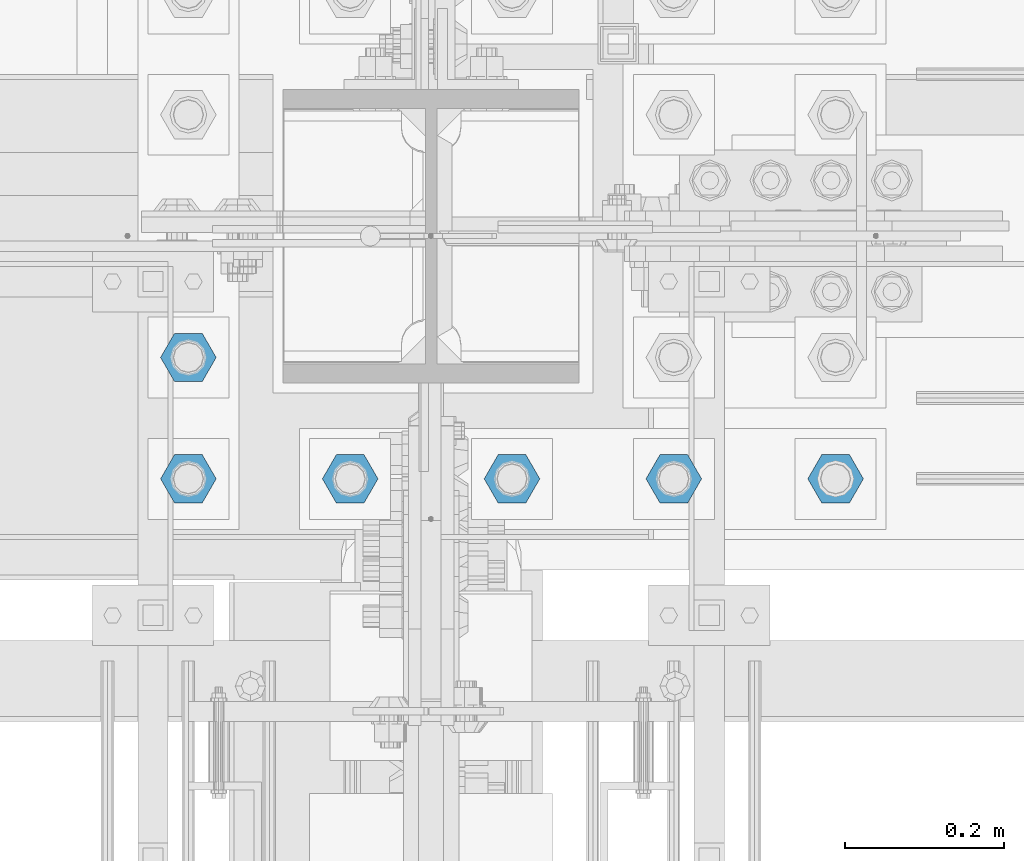
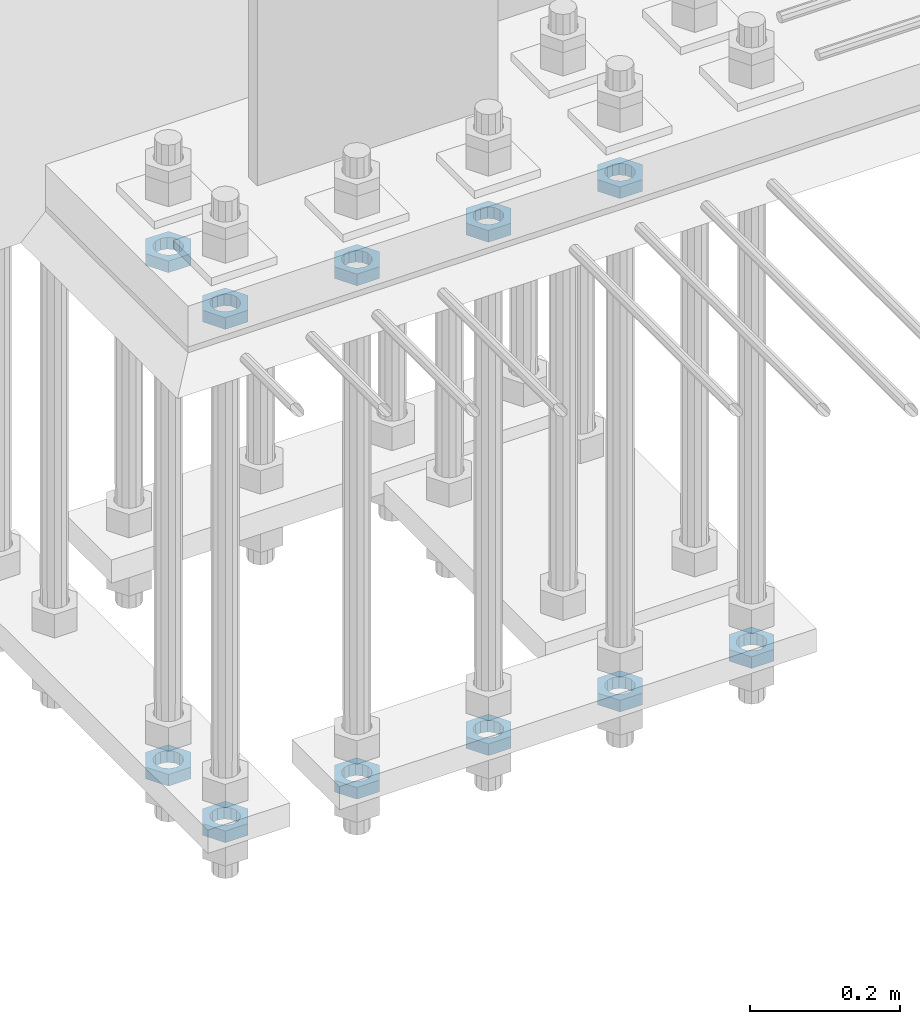
# One storey, part 2823 of 3843: 11 beams, 1 element without a shape of its own.
"""IFC2X3 building model written with IfcOpenShell, lengths in millimetres."""

from ifc_helpers import new_model, si_unit, frame, origin_with_axes, place, context, subcontext, project, spatial, faceted_brep, material, type_object, element, aggregate, save


model = new_model("IFC2X3")

# Units and contexts
model_context = context("Model", 3, precision=1e-05, world=origin_with_axes())
body_context = subcontext(model_context, "Body", "Model", "MODEL_VIEW")
ifc_project = project(units=[si_unit("LENGTHUNIT", "METRE", prefix="MILLI"), si_unit("AREAUNIT", "SQUARE_METRE"), si_unit("VOLUMEUNIT", "CUBIC_METRE"), si_unit("MASSUNIT", "GRAM", prefix="KILO"), si_unit("TIMEUNIT", "SECOND"), si_unit("PLANEANGLEUNIT", "RADIAN"), si_unit("SOLIDANGLEUNIT", "STERADIAN"), si_unit("THERMODYNAMICTEMPERATUREUNIT", "DEGREE_CELSIUS"), si_unit("LUMINOUSINTENSITYUNIT", "LUMEN")], contexts=[model_context])

# Site, building, storey
site_placement = place(None, origin_with_axes())
site = spatial("IfcSite", under=ifc_project, at=site_placement, CompositionType="ELEMENT")
building_placement = place(site_placement, origin_with_axes())
building = spatial("IfcBuilding", under=site, at=building_placement, Name="Undefined", CompositionType="ELEMENT")
storey_placement = place(building_placement, origin_with_axes())
storey = spatial("IfcBuildingStorey", under=building, at=storey_placement, Name="Undefined", CompositionType="ELEMENT", Elevation=0.0)

# Assembly, beams
assembly_placement = place(storey_placement, origin_with_axes())
assembly = element("IfcElementAssembly", 1, at=assembly_placement, inside=storey, Name="TEMPLATE", AssemblyPlace="NOTDEFINED", PredefinedType="RIGID_FRAME")
ifc_material = material(Name="STEEL/A572-50")
beam_type = type_object("IfcBeamType", Name="1-1/2_HALF_NUT", PredefinedType="NOTDEFINED")
beam_1_placement = place(assembly_placement, frame((56235.6, 25311.1, 29603.7), z_axis=(0.0, 1.0, 0.0), x_axis=(0.0, 0.0, -1.0)))
beam_1 = element("IfcBeam", 2, at=beam_1_placement, type_object=beam_type, material=ifc_material, Name="NUT", ObjectType="1-1/2_HALF_NUT", context=body_context, shape_type="Brep", body=[
    faceted_brep([(0.0, -34.9199981689453, 0.0), (0.0, -17.4599990844727, -30.25), (19.0500000000029, -17.4599990844727, -30.25), (19.0500000000029, -34.9199981689453, 0.0), (0.0, 17.4599990844727, -30.25), (19.0500000000029, 17.4599990844727, -30.25), (0.0, 34.9199981689453, 0.0), (19.0500000000029, 34.9199981689453, 0.0), (0.0, 17.4599990844727, 30.25), (19.0500000000029, 17.4599990844727, 30.25), (0.0, -17.4599990844727, 30.25), (19.0500000000029, -17.4599990844727, 30.25), (0.0, 0.0, 20.6399993896484), (0.0, 8.9553601105581, 18.5959968835959), (19.0500000000029, 8.95536011056538, 18.5959968835959), (19.0500000000029, 0.0, 20.6399993896484), (0.0, 16.1370013209525, 12.8688291298167), (19.0500000000029, 16.1370013209489, 12.8688291298167), (0.0, 20.1225115123816, 4.59283194104501), (19.0500000000029, 20.1225115123852, 4.59283194104501), (0.0, 20.1225115123816, -4.59283194104501), (19.0500000000029, 20.1225115123852, -4.59283194104501), (0.0, 16.1370013209525, -12.8688291298167), (19.0500000000029, 16.1370013209489, -12.8688291298167), (0.0, 8.9553601105581, -18.5959968835959), (19.0500000000029, 8.95536011056538, -18.5959968835959), (0.0, 0.0, -20.6399993896484), (19.0500000000029, 0.0, -20.6399993896484), (0.0, -8.9553601105581, -18.5959968835959), (19.0500000000029, -8.95536011056538, -18.5959968835959), (0.0, -16.1370013209525, -12.8688291298167), (19.0500000000029, -16.1370013209489, -12.8688291298167), (0.0, -20.1225115123816, -4.59283194104501), (19.0500000000029, -20.1225115123852, -4.59283194104501), (0.0, -20.1225115123816, 4.59283194104501), (19.0500000000029, -20.1225115123852, 4.59283194104501), (0.0, -16.1370013209525, 12.8688291298167), (19.0500000000029, -16.1370013209489, 12.8688291298167), (0.0, -8.9553601105581, 18.5959968835959), (19.0500000000029, -8.95536011056538, 18.5959968835959)], [[[0, 1, 2, 3]], [[1, 4, 5, 2]], [[4, 6, 7, 5]], [[6, 8, 9, 7]], [[8, 10, 11, 9]], [[10, 0, 3, 11]], [[12, 13, 14, 15]], [[13, 16, 17, 14]], [[16, 18, 19, 17]], [[18, 20, 21, 19]], [[20, 22, 23, 21]], [[22, 24, 25, 23]], [[24, 26, 27, 25]], [[26, 28, 29, 27]], [[28, 30, 31, 29]], [[30, 32, 33, 31]], [[32, 34, 35, 33]], [[34, 36, 37, 35]], [[36, 38, 39, 37]], [[38, 12, 15, 39]], [[5, 7, 9, 11, 3, 2], [17, 19, 21, 23, 25, 27, 29, 31, 33, 35, 37, 39, 15, 14]], [[10, 8, 6, 4, 1, 0], [38, 36, 34, 32, 30, 28, 26, 24, 22, 20, 18, 16, 13, 12]]]),
])
beam_2_placement = place(assembly_placement, frame((56032.4, 25311.1, 29603.7), z_axis=(0.0, -1.0, 0.0), x_axis=(0.0, 0.0, -1.0)))
beam_2 = element("IfcBeam", 3, at=beam_2_placement, type_object=beam_type, material=ifc_material, Name="NUT", ObjectType="1-1/2_HALF_NUT", context=body_context, shape_type="Brep", body=[
    faceted_brep([(0.0, -34.9199981689453, 0.0), (0.0, -17.4599990844727, -30.25), (19.0500000000029, -17.4599990844727, -30.25), (19.0500000000029, -34.9199981689453, 0.0), (0.0, 17.4599990844727, -30.25), (19.0500000000029, 17.4599990844727, -30.25), (0.0, 34.9199981689453, 0.0), (19.0500000000029, 34.9199981689453, 0.0), (0.0, 17.4599990844727, 30.25), (19.0500000000029, 17.4599990844727, 30.25), (0.0, -17.4599990844727, 30.25), (19.0500000000029, -17.4599990844727, 30.25), (0.0, 0.0, 20.6399993896484), (0.0, 8.9553601105581, 18.5959968835959), (19.0500000000029, 8.95536011056538, 18.5959968835959), (19.0500000000029, 0.0, 20.6399993896484), (0.0, 16.1370013209525, 12.8688291298167), (19.0500000000029, 16.1370013209489, 12.8688291298167), (0.0, 20.1225115123816, 4.59283194104501), (19.0500000000029, 20.1225115123852, 4.59283194104501), (0.0, 20.1225115123816, -4.59283194104501), (19.0500000000029, 20.1225115123852, -4.59283194104501), (0.0, 16.1370013209525, -12.8688291298167), (19.0500000000029, 16.1370013209489, -12.8688291298167), (0.0, 8.9553601105581, -18.5959968835959), (19.0500000000029, 8.95536011056538, -18.5959968835959), (0.0, 0.0, -20.6399993896484), (19.0500000000029, 0.0, -20.6399993896484), (0.0, -8.9553601105581, -18.5959968835959), (19.0500000000029, -8.95536011056538, -18.5959968835959), (0.0, -16.1370013209525, -12.8688291298167), (19.0500000000029, -16.1370013209489, -12.8688291298167), (0.0, -20.1225115123816, -4.59283194104501), (19.0500000000029, -20.1225115123852, -4.59283194104501), (0.0, -20.1225115123816, 4.59283194104501), (19.0500000000029, -20.1225115123852, 4.59283194104501), (0.0, -16.1370013209525, 12.8688291298167), (19.0500000000029, -16.1370013209489, 12.8688291298167), (0.0, -8.9553601105581, 18.5959968835959), (19.0500000000029, -8.95536011056538, 18.5959968835959)], [[[0, 1, 2, 3]], [[1, 4, 5, 2]], [[4, 6, 7, 5]], [[6, 8, 9, 7]], [[8, 10, 11, 9]], [[10, 0, 3, 11]], [[12, 13, 14, 15]], [[13, 16, 17, 14]], [[16, 18, 19, 17]], [[18, 20, 21, 19]], [[20, 22, 23, 21]], [[22, 24, 25, 23]], [[24, 26, 27, 25]], [[26, 28, 29, 27]], [[28, 30, 31, 29]], [[30, 32, 33, 31]], [[32, 34, 35, 33]], [[34, 36, 37, 35]], [[36, 38, 39, 37]], [[38, 12, 15, 39]], [[5, 7, 9, 11, 3, 2], [17, 19, 21, 23, 25, 27, 29, 31, 33, 35, 37, 39, 15, 14]], [[10, 8, 6, 4, 1, 0], [38, 36, 34, 32, 30, 28, 26, 24, 22, 20, 18, 16, 13, 12]]]),
])
beam_3_placement = place(assembly_placement, frame((55829.2, 25311.1, 29603.7), z_axis=(0.0, -1.0, 0.0), x_axis=(0.0, 0.0, -1.0)))
beam_3 = element("IfcBeam", 4, at=beam_3_placement, type_object=beam_type, material=ifc_material, Name="NUT", ObjectType="1-1/2_HALF_NUT", context=body_context, shape_type="Brep", body=[
    faceted_brep([(0.0, -34.9199981689453, 0.0), (0.0, -17.4599990844727, -30.25), (19.0500000000029, -17.4599990844727, -30.25), (19.0500000000029, -34.9199981689453, 0.0), (0.0, 17.4599990844727, -30.25), (19.0500000000029, 17.4599990844727, -30.25), (0.0, 34.9199981689453, 0.0), (19.0500000000029, 34.9199981689453, 0.0), (0.0, 17.4599990844727, 30.25), (19.0500000000029, 17.4599990844727, 30.25), (0.0, -17.4599990844727, 30.25), (19.0500000000029, -17.4599990844727, 30.25), (0.0, 0.0, 20.6399993896484), (0.0, 8.9553601105581, 18.5959968835959), (19.0500000000029, 8.95536011056538, 18.5959968835959), (19.0500000000029, 0.0, 20.6399993896484), (0.0, 16.1370013209525, 12.8688291298167), (19.0500000000029, 16.1370013209489, 12.8688291298167), (0.0, 20.1225115123816, 4.59283194104501), (19.0500000000029, 20.1225115123852, 4.59283194104501), (0.0, 20.1225115123816, -4.59283194104501), (19.0500000000029, 20.1225115123852, -4.59283194104501), (0.0, 16.1370013209525, -12.8688291298167), (19.0500000000029, 16.1370013209489, -12.8688291298167), (0.0, 8.9553601105581, -18.5959968835959), (19.0500000000029, 8.95536011056538, -18.5959968835959), (0.0, 0.0, -20.6399993896484), (19.0500000000029, 0.0, -20.6399993896484), (0.0, -8.9553601105581, -18.5959968835959), (19.0500000000029, -8.95536011056538, -18.5959968835959), (0.0, -16.1370013209525, -12.8688291298167), (19.0500000000029, -16.1370013209489, -12.8688291298167), (0.0, -20.1225115123816, -4.59283194104501), (19.0500000000029, -20.1225115123852, -4.59283194104501), (0.0, -20.1225115123816, 4.59283194104501), (19.0500000000029, -20.1225115123852, 4.59283194104501), (0.0, -16.1370013209525, 12.8688291298167), (19.0500000000029, -16.1370013209489, 12.8688291298167), (0.0, -8.9553601105581, 18.5959968835959), (19.0500000000029, -8.95536011056538, 18.5959968835959)], [[[0, 1, 2, 3]], [[1, 4, 5, 2]], [[4, 6, 7, 5]], [[6, 8, 9, 7]], [[8, 10, 11, 9]], [[10, 0, 3, 11]], [[12, 13, 14, 15]], [[13, 16, 17, 14]], [[16, 18, 19, 17]], [[18, 20, 21, 19]], [[20, 22, 23, 21]], [[22, 24, 25, 23]], [[24, 26, 27, 25]], [[26, 28, 29, 27]], [[28, 30, 31, 29]], [[30, 32, 33, 31]], [[32, 34, 35, 33]], [[34, 36, 37, 35]], [[36, 38, 39, 37]], [[38, 12, 15, 39]], [[5, 7, 9, 11, 3, 2], [17, 19, 21, 23, 25, 27, 29, 31, 33, 35, 37, 39, 15, 14]], [[10, 8, 6, 4, 1, 0], [38, 36, 34, 32, 30, 28, 26, 24, 22, 20, 18, 16, 13, 12]]]),
])
beam_4_placement = place(assembly_placement, frame((55626.0, 25463.5, 29603.7), z_axis=(0.0, -1.0, 0.0), x_axis=(0.0, 0.0, -1.0)))
beam_4 = element("IfcBeam", 5, at=beam_4_placement, type_object=beam_type, material=ifc_material, Name="NUT", ObjectType="1-1/2_HALF_NUT", context=body_context, shape_type="Brep", body=[
    faceted_brep([(0.0, -34.9199981689453, 0.0), (0.0, -17.4599990844727, -30.25), (19.0500000000029, -17.4599990844727, -30.25), (19.0500000000029, -34.9199981689453, 0.0), (0.0, 17.4599990844727, -30.25), (19.0500000000029, 17.4599990844727, -30.25), (0.0, 34.9199981689453, 0.0), (19.0500000000029, 34.9199981689453, 0.0), (0.0, 17.4599990844727, 30.25), (19.0500000000029, 17.4599990844727, 30.25), (0.0, -17.4599990844727, 30.25), (19.0500000000029, -17.4599990844727, 30.25), (0.0, 0.0, 20.6399993896484), (0.0, 8.9553601105581, 18.5959968835959), (19.0500000000029, 8.95536011056538, 18.5959968835959), (19.0500000000029, 0.0, 20.6399993896484), (0.0, 16.1370013209525, 12.8688291298167), (19.0500000000029, 16.1370013209489, 12.8688291298167), (0.0, 20.1225115123816, 4.59283194104501), (19.0500000000029, 20.1225115123852, 4.59283194104501), (0.0, 20.1225115123816, -4.59283194104501), (19.0500000000029, 20.1225115123852, -4.59283194104501), (0.0, 16.1370013209525, -12.8688291298167), (19.0500000000029, 16.1370013209489, -12.8688291298167), (0.0, 8.9553601105581, -18.5959968835959), (19.0500000000029, 8.95536011056538, -18.5959968835959), (0.0, 0.0, -20.6399993896484), (19.0500000000029, 0.0, -20.6399993896484), (0.0, -8.9553601105581, -18.5959968835959), (19.0500000000029, -8.95536011056538, -18.5959968835959), (0.0, -16.1370013209525, -12.8688291298167), (19.0500000000029, -16.1370013209489, -12.8688291298167), (0.0, -20.1225115123816, -4.59283194104501), (19.0500000000029, -20.1225115123852, -4.59283194104501), (0.0, -20.1225115123816, 4.59283194104501), (19.0500000000029, -20.1225115123852, 4.59283194104501), (0.0, -16.1370013209525, 12.8688291298167), (19.0500000000029, -16.1370013209489, 12.8688291298167), (0.0, -8.9553601105581, 18.5959968835959), (19.0500000000029, -8.95536011056538, 18.5959968835959)], [[[0, 1, 2, 3]], [[1, 4, 5, 2]], [[4, 6, 7, 5]], [[6, 8, 9, 7]], [[8, 10, 11, 9]], [[10, 0, 3, 11]], [[12, 13, 14, 15]], [[13, 16, 17, 14]], [[16, 18, 19, 17]], [[18, 20, 21, 19]], [[20, 22, 23, 21]], [[22, 24, 25, 23]], [[24, 26, 27, 25]], [[26, 28, 29, 27]], [[28, 30, 31, 29]], [[30, 32, 33, 31]], [[32, 34, 35, 33]], [[34, 36, 37, 35]], [[36, 38, 39, 37]], [[38, 12, 15, 39]], [[5, 7, 9, 11, 3, 2], [17, 19, 21, 23, 25, 27, 29, 31, 33, 35, 37, 39, 15, 14]], [[10, 8, 6, 4, 1, 0], [38, 36, 34, 32, 30, 28, 26, 24, 22, 20, 18, 16, 13, 12]]]),
])
beam_5_placement = place(assembly_placement, frame((55626.0, 25311.1, 29603.7), z_axis=(0.0, -1.0, 0.0), x_axis=(0.0, 0.0, -1.0)))
beam_5 = element("IfcBeam", 6, at=beam_5_placement, type_object=beam_type, material=ifc_material, Name="NUT", ObjectType="1-1/2_HALF_NUT", context=body_context, shape_type="Brep", body=[
    faceted_brep([(0.0, -34.9199981689453, 0.0), (0.0, -17.4599990844727, -30.25), (19.0500000000029, -17.4599990844727, -30.25), (19.0500000000029, -34.9199981689453, 0.0), (0.0, 17.4599990844727, -30.25), (19.0500000000029, 17.4599990844727, -30.25), (0.0, 34.9199981689453, 0.0), (19.0500000000029, 34.9199981689453, 0.0), (0.0, 17.4599990844727, 30.25), (19.0500000000029, 17.4599990844727, 30.25), (0.0, -17.4599990844727, 30.25), (19.0500000000029, -17.4599990844727, 30.25), (0.0, 0.0, 20.6399993896484), (0.0, 8.9553601105581, 18.5959968835959), (19.0500000000029, 8.95536011056538, 18.5959968835959), (19.0500000000029, 0.0, 20.6399993896484), (0.0, 16.1370013209525, 12.8688291298167), (19.0500000000029, 16.1370013209489, 12.8688291298167), (0.0, 20.1225115123816, 4.59283194104501), (19.0500000000029, 20.1225115123852, 4.59283194104501), (0.0, 20.1225115123816, -4.59283194104501), (19.0500000000029, 20.1225115123852, -4.59283194104501), (0.0, 16.1370013209525, -12.8688291298167), (19.0500000000029, 16.1370013209489, -12.8688291298167), (0.0, 8.9553601105581, -18.5959968835959), (19.0500000000029, 8.95536011056538, -18.5959968835959), (0.0, 0.0, -20.6399993896484), (19.0500000000029, 0.0, -20.6399993896484), (0.0, -8.9553601105581, -18.5959968835959), (19.0500000000029, -8.95536011056538, -18.5959968835959), (0.0, -16.1370013209525, -12.8688291298167), (19.0500000000029, -16.1370013209489, -12.8688291298167), (0.0, -20.1225115123816, -4.59283194104501), (19.0500000000029, -20.1225115123852, -4.59283194104501), (0.0, -20.1225115123816, 4.59283194104501), (19.0500000000029, -20.1225115123852, 4.59283194104501), (0.0, -16.1370013209525, 12.8688291298167), (19.0500000000029, -16.1370013209489, 12.8688291298167), (0.0, -8.9553601105581, 18.5959968835959), (19.0500000000029, -8.95536011056538, 18.5959968835959)], [[[0, 1, 2, 3]], [[1, 4, 5, 2]], [[4, 6, 7, 5]], [[6, 8, 9, 7]], [[8, 10, 11, 9]], [[10, 0, 3, 11]], [[12, 13, 14, 15]], [[13, 16, 17, 14]], [[16, 18, 19, 17]], [[18, 20, 21, 19]], [[20, 22, 23, 21]], [[22, 24, 25, 23]], [[24, 26, 27, 25]], [[26, 28, 29, 27]], [[28, 30, 31, 29]], [[30, 32, 33, 31]], [[32, 34, 35, 33]], [[34, 36, 37, 35]], [[36, 38, 39, 37]], [[38, 12, 15, 39]], [[5, 7, 9, 11, 3, 2], [17, 19, 21, 23, 25, 27, 29, 31, 33, 35, 37, 39, 15, 14]], [[10, 8, 6, 4, 1, 0], [38, 36, 34, 32, 30, 28, 26, 24, 22, 20, 18, 16, 13, 12]]]),
])
beam_6_placement = place(assembly_placement, frame((55626.0, 25311.1, 28765.5000015259), z_axis=(0.0, -1.0, 0.0), x_axis=(0.0, 0.0, -1.0)))
beam_6 = element("IfcBeam", 7, at=beam_6_placement, type_object=beam_type, material=ifc_material, Name="NUT", ObjectType="1-1/2_HALF_NUT", context=body_context, shape_type="Brep", body=[
    faceted_brep([(0.0, -34.9199981689453, 0.0), (0.0, -17.4599990844727, -30.25), (19.0500000000029, -17.4599990844727, -30.25), (19.0500000000029, -34.9199981689453, 0.0), (0.0, 17.4599990844727, -30.25), (19.0500000000029, 17.4599990844727, -30.25), (0.0, 34.9199981689453, 0.0), (19.0500000000029, 34.9199981689453, 0.0), (0.0, 17.4599990844727, 30.25), (19.0500000000029, 17.4599990844727, 30.25), (0.0, -17.4599990844727, 30.25), (19.0500000000029, -17.4599990844727, 30.25), (0.0, 0.0, 20.6399993896484), (0.0, 8.9553601105581, 18.5959968835959), (19.0500000000029, 8.95536011056538, 18.5959968835959), (19.0500000000029, 0.0, 20.6399993896484), (0.0, 16.1370013209525, 12.8688291298167), (19.0500000000029, 16.1370013209489, 12.8688291298167), (0.0, 20.1225115123816, 4.59283194104501), (19.0500000000029, 20.1225115123852, 4.59283194104501), (0.0, 20.1225115123816, -4.59283194104501), (19.0500000000029, 20.1225115123852, -4.59283194104501), (0.0, 16.1370013209525, -12.8688291298167), (19.0500000000029, 16.1370013209489, -12.8688291298167), (0.0, 8.9553601105581, -18.5959968835959), (19.0500000000029, 8.95536011056538, -18.5959968835959), (0.0, 0.0, -20.6399993896484), (19.0500000000029, 0.0, -20.6399993896484), (0.0, -8.9553601105581, -18.5959968835959), (19.0500000000029, -8.95536011056538, -18.5959968835959), (0.0, -16.1370013209525, -12.8688291298167), (19.0500000000029, -16.1370013209489, -12.8688291298167), (0.0, -20.1225115123816, -4.59283194104501), (19.0500000000029, -20.1225115123852, -4.59283194104501), (0.0, -20.1225115123816, 4.59283194104501), (19.0500000000029, -20.1225115123852, 4.59283194104501), (0.0, -16.1370013209525, 12.8688291298167), (19.0500000000029, -16.1370013209489, 12.8688291298167), (0.0, -8.9553601105581, 18.5959968835959), (19.0500000000029, -8.95536011056538, 18.5959968835959)], [[[0, 1, 2, 3]], [[1, 4, 5, 2]], [[4, 6, 7, 5]], [[6, 8, 9, 7]], [[8, 10, 11, 9]], [[10, 0, 3, 11]], [[12, 13, 14, 15]], [[13, 16, 17, 14]], [[16, 18, 19, 17]], [[18, 20, 21, 19]], [[20, 22, 23, 21]], [[22, 24, 25, 23]], [[24, 26, 27, 25]], [[26, 28, 29, 27]], [[28, 30, 31, 29]], [[30, 32, 33, 31]], [[32, 34, 35, 33]], [[34, 36, 37, 35]], [[36, 38, 39, 37]], [[38, 12, 15, 39]], [[5, 7, 9, 11, 3, 2], [17, 19, 21, 23, 25, 27, 29, 31, 33, 35, 37, 39, 15, 14]], [[10, 8, 6, 4, 1, 0], [38, 36, 34, 32, 30, 28, 26, 24, 22, 20, 18, 16, 13, 12]]]),
])
beam_7_placement = place(assembly_placement, frame((55829.2, 25311.1, 28765.5000015259), z_axis=(0.0, -1.0, 0.0), x_axis=(0.0, 0.0, -1.0)))
beam_7 = element("IfcBeam", 8, at=beam_7_placement, type_object=beam_type, material=ifc_material, Name="NUT", ObjectType="1-1/2_HALF_NUT", context=body_context, shape_type="Brep", body=[
    faceted_brep([(0.0, -34.9199981689453, 0.0), (0.0, -17.4599990844727, -30.25), (19.0500000000029, -17.4599990844727, -30.25), (19.0500000000029, -34.9199981689453, 0.0), (0.0, 17.4599990844727, -30.25), (19.0500000000029, 17.4599990844727, -30.25), (0.0, 34.9199981689453, 0.0), (19.0500000000029, 34.9199981689453, 0.0), (0.0, 17.4599990844727, 30.25), (19.0500000000029, 17.4599990844727, 30.25), (0.0, -17.4599990844727, 30.25), (19.0500000000029, -17.4599990844727, 30.25), (0.0, 0.0, 20.6399993896484), (0.0, 8.9553601105581, 18.5959968835959), (19.0500000000029, 8.95536011056538, 18.5959968835959), (19.0500000000029, 0.0, 20.6399993896484), (0.0, 16.1370013209525, 12.8688291298167), (19.0500000000029, 16.1370013209489, 12.8688291298167), (0.0, 20.1225115123816, 4.59283194104501), (19.0500000000029, 20.1225115123852, 4.59283194104501), (0.0, 20.1225115123816, -4.59283194104501), (19.0500000000029, 20.1225115123852, -4.59283194104501), (0.0, 16.1370013209525, -12.8688291298167), (19.0500000000029, 16.1370013209489, -12.8688291298167), (0.0, 8.9553601105581, -18.5959968835959), (19.0500000000029, 8.95536011056538, -18.5959968835959), (0.0, 0.0, -20.6399993896484), (19.0500000000029, 0.0, -20.6399993896484), (0.0, -8.9553601105581, -18.5959968835959), (19.0500000000029, -8.95536011056538, -18.5959968835959), (0.0, -16.1370013209525, -12.8688291298167), (19.0500000000029, -16.1370013209489, -12.8688291298167), (0.0, -20.1225115123816, -4.59283194104501), (19.0500000000029, -20.1225115123852, -4.59283194104501), (0.0, -20.1225115123816, 4.59283194104501), (19.0500000000029, -20.1225115123852, 4.59283194104501), (0.0, -16.1370013209525, 12.8688291298167), (19.0500000000029, -16.1370013209489, 12.8688291298167), (0.0, -8.9553601105581, 18.5959968835959), (19.0500000000029, -8.95536011056538, 18.5959968835959)], [[[0, 1, 2, 3]], [[1, 4, 5, 2]], [[4, 6, 7, 5]], [[6, 8, 9, 7]], [[8, 10, 11, 9]], [[10, 0, 3, 11]], [[12, 13, 14, 15]], [[13, 16, 17, 14]], [[16, 18, 19, 17]], [[18, 20, 21, 19]], [[20, 22, 23, 21]], [[22, 24, 25, 23]], [[24, 26, 27, 25]], [[26, 28, 29, 27]], [[28, 30, 31, 29]], [[30, 32, 33, 31]], [[32, 34, 35, 33]], [[34, 36, 37, 35]], [[36, 38, 39, 37]], [[38, 12, 15, 39]], [[5, 7, 9, 11, 3, 2], [17, 19, 21, 23, 25, 27, 29, 31, 33, 35, 37, 39, 15, 14]], [[10, 8, 6, 4, 1, 0], [38, 36, 34, 32, 30, 28, 26, 24, 22, 20, 18, 16, 13, 12]]]),
])
beam_8_placement = place(assembly_placement, frame((56032.4, 25311.1, 28765.5000015259), z_axis=(0.0, -1.0, 0.0), x_axis=(0.0, 0.0, -1.0)))
beam_8 = element("IfcBeam", 9, at=beam_8_placement, type_object=beam_type, material=ifc_material, Name="NUT", ObjectType="1-1/2_HALF_NUT", context=body_context, shape_type="Brep", body=[
    faceted_brep([(0.0, -34.9199981689453, 0.0), (0.0, -17.4599990844727, -30.25), (19.0500000000029, -17.4599990844727, -30.25), (19.0500000000029, -34.9199981689453, 0.0), (0.0, 17.4599990844727, -30.25), (19.0500000000029, 17.4599990844727, -30.25), (0.0, 34.9199981689453, 0.0), (19.0500000000029, 34.9199981689453, 0.0), (0.0, 17.4599990844727, 30.25), (19.0500000000029, 17.4599990844727, 30.25), (0.0, -17.4599990844727, 30.25), (19.0500000000029, -17.4599990844727, 30.25), (0.0, 0.0, 20.6399993896484), (0.0, 8.9553601105581, 18.5959968835959), (19.0500000000029, 8.95536011056538, 18.5959968835959), (19.0500000000029, 0.0, 20.6399993896484), (0.0, 16.1370013209525, 12.8688291298167), (19.0500000000029, 16.1370013209489, 12.8688291298167), (0.0, 20.1225115123816, 4.59283194104501), (19.0500000000029, 20.1225115123852, 4.59283194104501), (0.0, 20.1225115123816, -4.59283194104501), (19.0500000000029, 20.1225115123852, -4.59283194104501), (0.0, 16.1370013209525, -12.8688291298167), (19.0500000000029, 16.1370013209489, -12.8688291298167), (0.0, 8.9553601105581, -18.5959968835959), (19.0500000000029, 8.95536011056538, -18.5959968835959), (0.0, 0.0, -20.6399993896484), (19.0500000000029, 0.0, -20.6399993896484), (0.0, -8.9553601105581, -18.5959968835959), (19.0500000000029, -8.95536011056538, -18.5959968835959), (0.0, -16.1370013209525, -12.8688291298167), (19.0500000000029, -16.1370013209489, -12.8688291298167), (0.0, -20.1225115123816, -4.59283194104501), (19.0500000000029, -20.1225115123852, -4.59283194104501), (0.0, -20.1225115123816, 4.59283194104501), (19.0500000000029, -20.1225115123852, 4.59283194104501), (0.0, -16.1370013209525, 12.8688291298167), (19.0500000000029, -16.1370013209489, 12.8688291298167), (0.0, -8.9553601105581, 18.5959968835959), (19.0500000000029, -8.95536011056538, 18.5959968835959)], [[[0, 1, 2, 3]], [[1, 4, 5, 2]], [[4, 6, 7, 5]], [[6, 8, 9, 7]], [[8, 10, 11, 9]], [[10, 0, 3, 11]], [[12, 13, 14, 15]], [[13, 16, 17, 14]], [[16, 18, 19, 17]], [[18, 20, 21, 19]], [[20, 22, 23, 21]], [[22, 24, 25, 23]], [[24, 26, 27, 25]], [[26, 28, 29, 27]], [[28, 30, 31, 29]], [[30, 32, 33, 31]], [[32, 34, 35, 33]], [[34, 36, 37, 35]], [[36, 38, 39, 37]], [[38, 12, 15, 39]], [[5, 7, 9, 11, 3, 2], [17, 19, 21, 23, 25, 27, 29, 31, 33, 35, 37, 39, 15, 14]], [[10, 8, 6, 4, 1, 0], [38, 36, 34, 32, 30, 28, 26, 24, 22, 20, 18, 16, 13, 12]]]),
])
beam_9_placement = place(assembly_placement, frame((56235.6, 25311.1, 28765.5000015259), z_axis=(0.0, 1.0, 0.0), x_axis=(0.0, 0.0, -1.0)))
beam_9 = element("IfcBeam", 10, at=beam_9_placement, type_object=beam_type, material=ifc_material, Name="NUT", ObjectType="1-1/2_HALF_NUT", context=body_context, shape_type="Brep", body=[
    faceted_brep([(0.0, -34.9199981689453, 0.0), (0.0, -17.4599990844727, -30.25), (19.0500000000029, -17.4599990844727, -30.25), (19.0500000000029, -34.9199981689453, 0.0), (0.0, 17.4599990844727, -30.25), (19.0500000000029, 17.4599990844727, -30.25), (0.0, 34.9199981689453, 0.0), (19.0500000000029, 34.9199981689453, 0.0), (0.0, 17.4599990844727, 30.25), (19.0500000000029, 17.4599990844727, 30.25), (0.0, -17.4599990844727, 30.25), (19.0500000000029, -17.4599990844727, 30.25), (0.0, 0.0, 20.6399993896484), (0.0, 8.9553601105581, 18.5959968835959), (19.0500000000029, 8.95536011056538, 18.5959968835959), (19.0500000000029, 0.0, 20.6399993896484), (0.0, 16.1370013209525, 12.8688291298167), (19.0500000000029, 16.1370013209489, 12.8688291298167), (0.0, 20.1225115123816, 4.59283194104501), (19.0500000000029, 20.1225115123852, 4.59283194104501), (0.0, 20.1225115123816, -4.59283194104501), (19.0500000000029, 20.1225115123852, -4.59283194104501), (0.0, 16.1370013209525, -12.8688291298167), (19.0500000000029, 16.1370013209489, -12.8688291298167), (0.0, 8.9553601105581, -18.5959968835959), (19.0500000000029, 8.95536011056538, -18.5959968835959), (0.0, 0.0, -20.6399993896484), (19.0500000000029, 0.0, -20.6399993896484), (0.0, -8.9553601105581, -18.5959968835959), (19.0500000000029, -8.95536011056538, -18.5959968835959), (0.0, -16.1370013209525, -12.8688291298167), (19.0500000000029, -16.1370013209489, -12.8688291298167), (0.0, -20.1225115123816, -4.59283194104501), (19.0500000000029, -20.1225115123852, -4.59283194104501), (0.0, -20.1225115123816, 4.59283194104501), (19.0500000000029, -20.1225115123852, 4.59283194104501), (0.0, -16.1370013209525, 12.8688291298167), (19.0500000000029, -16.1370013209489, 12.8688291298167), (0.0, -8.9553601105581, 18.5959968835959), (19.0500000000029, -8.95536011056538, 18.5959968835959)], [[[0, 1, 2, 3]], [[1, 4, 5, 2]], [[4, 6, 7, 5]], [[6, 8, 9, 7]], [[8, 10, 11, 9]], [[10, 0, 3, 11]], [[12, 13, 14, 15]], [[13, 16, 17, 14]], [[16, 18, 19, 17]], [[18, 20, 21, 19]], [[20, 22, 23, 21]], [[22, 24, 25, 23]], [[24, 26, 27, 25]], [[26, 28, 29, 27]], [[28, 30, 31, 29]], [[30, 32, 33, 31]], [[32, 34, 35, 33]], [[34, 36, 37, 35]], [[36, 38, 39, 37]], [[38, 12, 15, 39]], [[5, 7, 9, 11, 3, 2], [17, 19, 21, 23, 25, 27, 29, 31, 33, 35, 37, 39, 15, 14]], [[10, 8, 6, 4, 1, 0], [38, 36, 34, 32, 30, 28, 26, 24, 22, 20, 18, 16, 13, 12]]]),
])
beam_10_placement = place(assembly_placement, frame((56438.800025177, 25311.1, 28765.5), z_axis=(0.0, 1.0, 0.0), x_axis=(0.0, 0.0, -1.0)))
beam_10 = element("IfcBeam", 11, at=beam_10_placement, type_object=beam_type, material=ifc_material, Name="NUT", ObjectType="1-1/2_HALF_NUT", context=body_context, shape_type="Brep", body=[
    faceted_brep([(0.0, -34.9199981689453, 0.0), (0.0, -17.4599990844727, -30.25), (19.0500000000029, -17.4599990844727, -30.25), (19.0500000000029, -34.9199981689453, 0.0), (0.0, 17.4599990844727, -30.25), (19.0500000000029, 17.4599990844727, -30.25), (0.0, 34.9199981689453, 0.0), (19.0500000000029, 34.9199981689453, 0.0), (0.0, 17.4599990844727, 30.25), (19.0500000000029, 17.4599990844727, 30.25), (0.0, -17.4599990844727, 30.25), (19.0500000000029, -17.4599990844727, 30.25), (0.0, 0.0, 20.6399993896484), (0.0, 8.9553601105581, 18.5959968835959), (19.0500000000029, 8.95536011056538, 18.5959968835959), (19.0500000000029, 0.0, 20.6399993896484), (0.0, 16.1370013209525, 12.8688291298167), (19.0500000000029, 16.1370013209489, 12.8688291298167), (0.0, 20.1225115123816, 4.59283194104501), (19.0500000000029, 20.1225115123852, 4.59283194104501), (0.0, 20.1225115123816, -4.59283194104501), (19.0500000000029, 20.1225115123852, -4.59283194104501), (0.0, 16.1370013209525, -12.8688291298167), (19.0500000000029, 16.1370013209489, -12.8688291298167), (0.0, 8.9553601105581, -18.5959968835959), (19.0500000000029, 8.95536011056538, -18.5959968835959), (0.0, 0.0, -20.6399993896484), (19.0500000000029, 0.0, -20.6399993896484), (0.0, -8.9553601105581, -18.5959968835959), (19.0500000000029, -8.95536011056538, -18.5959968835959), (0.0, -16.1370013209525, -12.8688291298167), (19.0500000000029, -16.1370013209489, -12.8688291298167), (0.0, -20.1225115123816, -4.59283194104501), (19.0500000000029, -20.1225115123852, -4.59283194104501), (0.0, -20.1225115123816, 4.59283194104501), (19.0500000000029, -20.1225115123852, 4.59283194104501), (0.0, -16.1370013209525, 12.8688291298167), (19.0500000000029, -16.1370013209489, 12.8688291298167), (0.0, -8.9553601105581, 18.5959968835959), (19.0500000000029, -8.95536011056538, 18.5959968835959)], [[[0, 1, 2, 3]], [[1, 4, 5, 2]], [[4, 6, 7, 5]], [[6, 8, 9, 7]], [[8, 10, 11, 9]], [[10, 0, 3, 11]], [[12, 13, 14, 15]], [[13, 16, 17, 14]], [[16, 18, 19, 17]], [[18, 20, 21, 19]], [[20, 22, 23, 21]], [[22, 24, 25, 23]], [[24, 26, 27, 25]], [[26, 28, 29, 27]], [[28, 30, 31, 29]], [[30, 32, 33, 31]], [[32, 34, 35, 33]], [[34, 36, 37, 35]], [[36, 38, 39, 37]], [[38, 12, 15, 39]], [[5, 7, 9, 11, 3, 2], [17, 19, 21, 23, 25, 27, 29, 31, 33, 35, 37, 39, 15, 14]], [[10, 8, 6, 4, 1, 0], [38, 36, 34, 32, 30, 28, 26, 24, 22, 20, 18, 16, 13, 12]]]),
])
beam_11_placement = place(assembly_placement, frame((55626.0, 25463.5, 28765.5000015259), z_axis=(0.0, -1.0, 0.0), x_axis=(0.0, 0.0, -1.0)))
beam_11 = element("IfcBeam", 12, at=beam_11_placement, type_object=beam_type, material=ifc_material, Name="NUT", ObjectType="1-1/2_HALF_NUT", context=body_context, shape_type="Brep", body=[
    faceted_brep([(0.0, -34.9199981689453, 0.0), (0.0, -17.4599990844727, -30.25), (19.0500000000029, -17.4599990844727, -30.25), (19.0500000000029, -34.9199981689453, 0.0), (0.0, 17.4599990844727, -30.25), (19.0500000000029, 17.4599990844727, -30.25), (0.0, 34.9199981689453, 0.0), (19.0500000000029, 34.9199981689453, 0.0), (0.0, 17.4599990844727, 30.25), (19.0500000000029, 17.4599990844727, 30.25), (0.0, -17.4599990844727, 30.25), (19.0500000000029, -17.4599990844727, 30.25), (0.0, 0.0, 20.6399993896484), (0.0, 8.9553601105581, 18.5959968835959), (19.0500000000029, 8.95536011056538, 18.5959968835959), (19.0500000000029, 0.0, 20.6399993896484), (0.0, 16.1370013209525, 12.8688291298167), (19.0500000000029, 16.1370013209489, 12.8688291298167), (0.0, 20.1225115123816, 4.59283194104501), (19.0500000000029, 20.1225115123852, 4.59283194104501), (0.0, 20.1225115123816, -4.59283194104501), (19.0500000000029, 20.1225115123852, -4.59283194104501), (0.0, 16.1370013209525, -12.8688291298167), (19.0500000000029, 16.1370013209489, -12.8688291298167), (0.0, 8.9553601105581, -18.5959968835959), (19.0500000000029, 8.95536011056538, -18.5959968835959), (0.0, 0.0, -20.6399993896484), (19.0500000000029, 0.0, -20.6399993896484), (0.0, -8.9553601105581, -18.5959968835959), (19.0500000000029, -8.95536011056538, -18.5959968835959), (0.0, -16.1370013209525, -12.8688291298167), (19.0500000000029, -16.1370013209489, -12.8688291298167), (0.0, -20.1225115123816, -4.59283194104501), (19.0500000000029, -20.1225115123852, -4.59283194104501), (0.0, -20.1225115123816, 4.59283194104501), (19.0500000000029, -20.1225115123852, 4.59283194104501), (0.0, -16.1370013209525, 12.8688291298167), (19.0500000000029, -16.1370013209489, 12.8688291298167), (0.0, -8.9553601105581, 18.5959968835959), (19.0500000000029, -8.95536011056538, 18.5959968835959)], [[[0, 1, 2, 3]], [[1, 4, 5, 2]], [[4, 6, 7, 5]], [[6, 8, 9, 7]], [[8, 10, 11, 9]], [[10, 0, 3, 11]], [[12, 13, 14, 15]], [[13, 16, 17, 14]], [[16, 18, 19, 17]], [[18, 20, 21, 19]], [[20, 22, 23, 21]], [[22, 24, 25, 23]], [[24, 26, 27, 25]], [[26, 28, 29, 27]], [[28, 30, 31, 29]], [[30, 32, 33, 31]], [[32, 34, 35, 33]], [[34, 36, 37, 35]], [[36, 38, 39, 37]], [[38, 12, 15, 39]], [[5, 7, 9, 11, 3, 2], [17, 19, 21, 23, 25, 27, 29, 31, 33, 35, 37, 39, 15, 14]], [[10, 8, 6, 4, 1, 0], [38, 36, 34, 32, 30, 28, 26, 24, 22, 20, 18, 16, 13, 12]]]),
])
aggregate(assembly, [beam_1, beam_2, beam_3, beam_4, beam_5, beam_6, beam_7, beam_8, beam_9, beam_10, beam_11])

save(model, "model.ifc")
